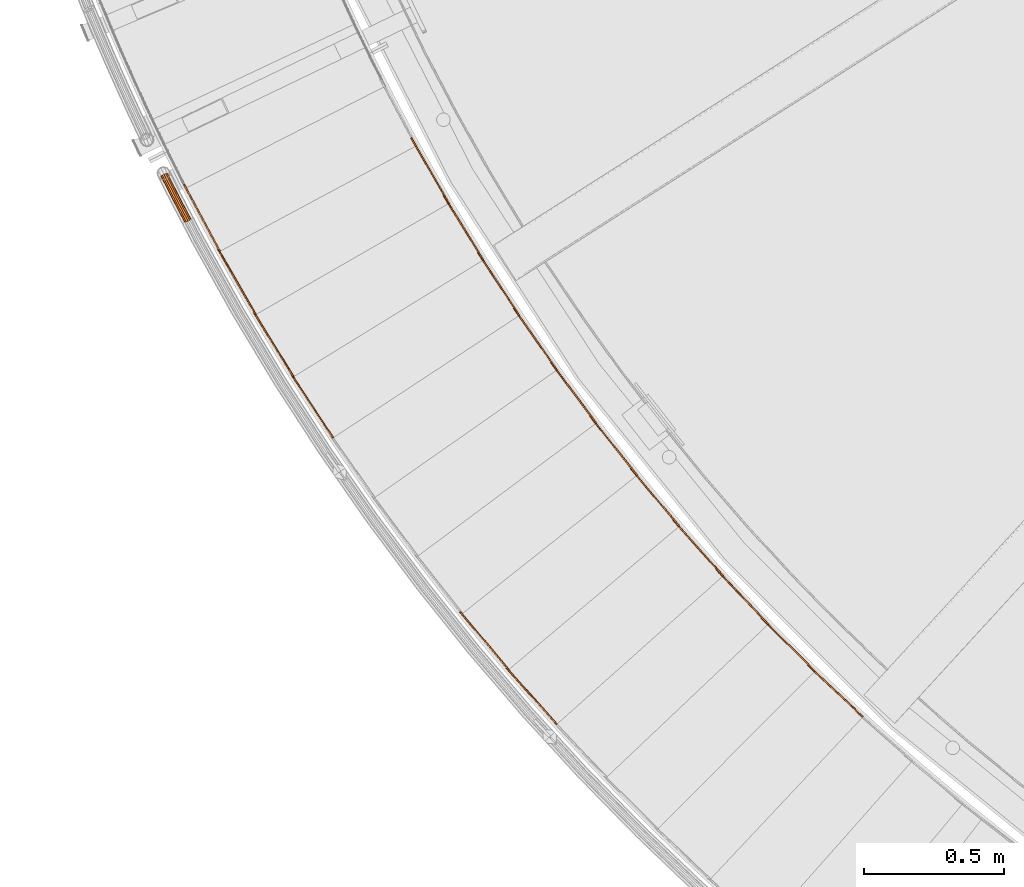
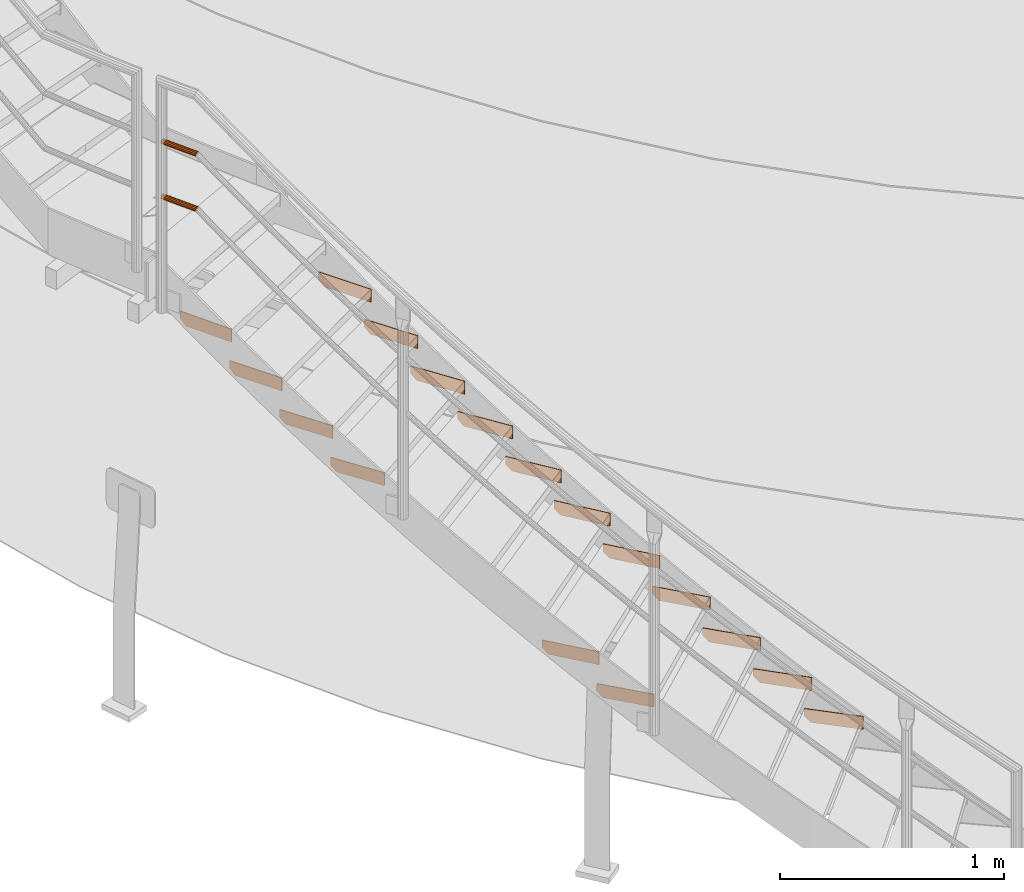
# One storey, part 45 of 126: 19 proxies.
"""IFC2X3 building model written with IfcOpenShell, lengths in millimetres."""

from ifc_helpers import new_model, si_unit, origin, origin_with_axes, place, context, project, spatial, faceted_brep, material, element, save


model = new_model("IFC2X3")

# Units and contexts
context_of_model_1 = context(None, 3, precision=0.1, world=origin())
context_of_model_2 = context(None, 3, precision=0.1, world=origin())
ifc_project = project(units=[si_unit("LENGTHUNIT", "METRE", prefix="MILLI"), si_unit("AREAUNIT", "SQUARE_METRE", prefix="CENTI"), si_unit("VOLUMEUNIT", "CUBIC_METRE", prefix="CENTI"), si_unit("MASSUNIT", "GRAM", prefix="KILO")], contexts=[context_of_model_1, context_of_model_2])

# Site, building, storey
site_placement = place(None, origin_with_axes())
site = spatial("IfcSite", under=ifc_project, at=site_placement, CompositionType="ELEMENT")
building_placement = place(site_placement, origin_with_axes())
building = spatial("IfcBuilding", under=site, at=building_placement, CompositionType="ELEMENT")
storey_placement = place(building_placement, origin_with_axes())
storey = spatial("IfcBuildingStorey", under=building, at=storey_placement, CompositionType="ELEMENT")

# Proxies
ifc_material = material(Name="S235JRG2")
proxy_1_placement = place(storey_placement, origin_with_axes())
element("IfcBuildingElementProxy", 1, at=proxy_1_placement, inside=storey, material=ifc_material, context=context_of_model_2, shape_type="Brep", body=[
    faceted_brep([(2566.2989, 2108.1136, 622.69), (2569.7223, 2111.7578, 622.69), (2569.7223, 2111.7578, 692.69), (2566.2989, 2108.1136, 692.69), (2369.5096, 2292.9755, 692.69), (2372.9329, 2296.6198, 692.69), (2372.9329, 2296.6198, 652.69), (2369.5096, 2292.9755, 652.69), (2391.375, 2272.4353, 622.69), (2394.7984, 2276.0795, 622.69)], [[[0, 1, 2, 3]], [[4, 5, 6, 7]], [[0, 8, 9, 1]], [[1, 9, 6, 5, 2]], [[2, 5, 4, 3]], [[0, 3, 4, 7, 8]], [[6, 9, 8, 7]]]),
])
proxy_2_placement = place(storey_placement, origin_with_axes())
element("IfcBuildingElementProxy", 2, at=proxy_2_placement, inside=storey, material=ifc_material, context=context_of_model_2, shape_type="Brep", body=[
    faceted_brep([(2395.0892, 2270.7485, 795.85), (2398.6183, 2274.2905, 795.85), (2398.6183, 2274.2905, 865.85), (2395.0892, 2270.7485, 865.85), (2203.8262, 2461.3226, 865.85), (2207.3554, 2464.8645, 865.85), (2207.3554, 2464.8645, 825.85), (2203.8262, 2461.3226, 825.85), (2225.0777, 2440.1477, 795.85), (2228.6068, 2443.6896, 795.85)], [[[0, 1, 2, 3]], [[4, 5, 6, 7]], [[0, 8, 9, 1]], [[1, 9, 6, 5, 2]], [[2, 5, 4, 3]], [[0, 3, 4, 7, 8]], [[6, 9, 8, 7]]]),
])
proxy_3_placement = place(storey_placement, origin_with_axes())
element("IfcBuildingElementProxy", 3, at=proxy_3_placement, inside=storey, material=ifc_material, context=context_of_model_2, shape_type="Brep", body=[
    faceted_brep([(2228.7405, 2438.3524, 969.01), (2232.3724, 2441.7889, 969.01), (2232.3724, 2441.7889, 1039.01), (2228.7405, 2438.3524, 1039.01), (2043.1697, 2634.4734, 1039.01), (2046.8016, 2637.9099, 1039.01), (2046.8016, 2637.9099, 999.01), (2043.1697, 2634.4734, 999.01), (2063.7887, 2612.6822, 969.01), (2067.4205, 2616.1187, 969.01)], [[[0, 1, 2, 3]], [[4, 5, 6, 7]], [[0, 8, 9, 1]], [[1, 9, 6, 5, 2]], [[2, 5, 4, 3]], [[0, 3, 4, 7, 8]], [[6, 9, 8, 7]]]),
])
proxy_4_placement = place(storey_placement, origin_with_axes())
element("IfcBuildingElementProxy", 4, at=proxy_4_placement, inside=storey, material=ifc_material, context=context_of_model_2, shape_type="Brep", body=[
    faceted_brep([(2067.3971, 2610.7798, 1142.17), (2071.1286, 2614.1079, 1142.17), (2071.1286, 2614.1079, 1212.17), (2067.3971, 2610.7798, 1212.17), (1887.6792, 2812.2779, 1212.17), (1891.4107, 2815.606, 1212.17), (1891.4107, 2815.606, 1172.17), (1887.6792, 2812.2779, 1172.17), (1907.6479, 2789.8892, 1142.17), (1911.3793, 2793.2173, 1142.17)], [[[0, 1, 2, 3]], [[4, 5, 6, 7]], [[0, 8, 9, 1]], [[1, 9, 6, 5, 2]], [[2, 5, 4, 3]], [[0, 3, 4, 7, 8]], [[6, 9, 8, 7]]]),
])
proxy_5_placement = place(storey_placement, origin_with_axes())
element("IfcBuildingElementProxy", 5, at=proxy_5_placement, inside=storey, material=ifc_material, context=context_of_model_2, shape_type="Brep", body=[
    faceted_brep([(1474.0973, 2081.6104, 1142.17), (1477.8287, 2084.9385, 1142.17), (1477.8287, 2084.9385, 1212.17), (1474.0973, 2081.6104, 1212.17), (1294.3793, 2283.1085, 1212.17), (1298.1108, 2286.4366, 1212.17), (1298.1108, 2286.4366, 1172.17), (1294.3793, 2283.1085, 1172.17), (1314.348, 2260.7198, 1142.17), (1318.0794, 2264.0479, 1142.17)], [[[0, 1, 2, 3]], [[4, 5, 6, 7]], [[0, 8, 9, 1]], [[1, 9, 6, 5, 2]], [[2, 5, 4, 3]], [[0, 3, 4, 7, 8]], [[6, 9, 8, 7]]]),
])
proxy_6_placement = place(storey_placement, origin_with_axes())
element("IfcBuildingElementProxy", 6, at=proxy_6_placement, inside=storey, material=ifc_material, context=context_of_model_2, shape_type="Brep", body=[
    faceted_brep([(1911.1988, 2787.8815, 1315.33), (1915.0266, 2791.0983, 1315.33), (1915.0266, 2791.0983, 1385.33), (1911.1988, 2787.8815, 1385.33), (1737.4895, 2994.582, 1385.33), (1741.3173, 2997.7988, 1385.33), (1741.3173, 2997.7988, 1345.33), (1737.4895, 2994.582, 1345.33), (1756.7906, 2971.6153, 1315.33), (1760.6183, 2974.8321, 1315.33)], [[[0, 1, 2, 3]], [[4, 5, 6, 7]], [[0, 8, 9, 1]], [[1, 9, 6, 5, 2]], [[2, 5, 4, 3]], [[0, 3, 4, 7, 8]], [[6, 9, 8, 7]]]),
])
proxy_7_placement = place(storey_placement, origin_with_axes())
element("IfcBuildingElementProxy", 7, at=proxy_7_placement, inside=storey, material=ifc_material, context=context_of_model_2, shape_type="Brep", body=[
    faceted_brep([(1302.5806, 2276.4042, 1315.33), (1306.4084, 2279.6211, 1315.33), (1306.4084, 2279.6211, 1385.33), (1302.5806, 2276.4042, 1385.33), (1128.8714, 2483.1047, 1385.33), (1132.6992, 2486.3216, 1385.33), (1132.6992, 2486.3216, 1345.33), (1128.8714, 2483.1047, 1345.33), (1148.1724, 2460.138, 1315.33), (1152.0002, 2463.3549, 1315.33)], [[[0, 1, 2, 3]], [[4, 5, 6, 7]], [[0, 8, 9, 1]], [[1, 9, 6, 5, 2]], [[2, 5, 4, 3]], [[0, 3, 4, 7, 8]], [[6, 9, 8, 7]]]),
])
proxy_8_placement = place(storey_placement, origin_with_axes())
element("IfcBuildingElementProxy", 8, at=proxy_8_placement, inside=storey, material=ifc_material, context=context_of_model_2, shape_type="Brep", body=[
    faceted_brep([(1760.2808, 2969.5039, 1488.49), (1764.2016, 2972.6066, 1488.49), (1764.2016, 2972.6066, 1558.49), (1760.2808, 2969.5039, 1558.49), (1592.7308, 3181.2277, 1558.49), (1596.6516, 3184.3305, 1558.49), (1596.6516, 3184.3305, 1518.49), (1592.7308, 3181.2277, 1518.49), (1611.3474, 3157.7028, 1488.49), (1615.2682, 3160.8056, 1488.49)], [[[0, 1, 2, 3]], [[4, 5, 6, 7]], [[0, 8, 9, 1]], [[1, 9, 6, 5, 2]], [[2, 5, 4, 3]], [[0, 3, 4, 7, 8]], [[6, 9, 8, 7]]]),
])
proxy_9_placement = place(storey_placement, origin_with_axes())
element("IfcBuildingElementProxy", 9, at=proxy_9_placement, inside=storey, material=ifc_material, context=context_of_model_2, shape_type="Brep", body=[
    faceted_brep([(1614.774, 3155.4896, 1661.65), (1618.7845, 3158.4756, 1661.65), (1618.7845, 3158.4756, 1731.65), (1614.774, 3155.4896, 1731.65), (1453.5283, 3372.0533, 1731.65), (1457.5388, 3375.0393, 1731.65), (1457.5388, 3375.0393, 1691.65), (1453.5283, 3372.0533, 1691.65), (1471.4445, 3347.9906, 1661.65), (1475.455, 3350.9767, 1661.65)], [[[0, 1, 2, 3]], [[4, 5, 6, 7]], [[0, 8, 9, 1]], [[1, 9, 6, 5, 2]], [[2, 5, 4, 3]], [[0, 3, 4, 7, 8]], [[6, 9, 8, 7]]]),
])
proxy_10_placement = place(storey_placement, origin_with_axes())
element("IfcBuildingElementProxy", 10, at=proxy_10_placement, inside=storey, material=ifc_material, context=context_of_model_2, shape_type="Brep", body=[
    faceted_brep([(1474.8045, 3345.6775, 1834.81), (1478.9011, 3348.5442, 1834.81), (1478.9011, 3348.5442, 1904.81), (1474.8045, 3345.6775, 1904.81), (1320.0029, 3566.8934, 1904.81), (1324.0995, 3569.7601, 1904.81), (1324.0995, 3569.7601, 1864.81), (1320.0029, 3566.8934, 1864.81), (1337.2031, 3542.3139, 1834.81), (1341.2997, 3545.1806, 1834.81)], [[[0, 1, 2, 3]], [[4, 5, 6, 7]], [[0, 8, 9, 1]], [[1, 9, 6, 5, 2]], [[2, 5, 4, 3]], [[0, 3, 4, 7, 8]], [[6, 9, 8, 7]]]),
])
proxy_11_placement = place(storey_placement, origin_with_axes())
element("IfcBuildingElementProxy", 11, at=proxy_11_placement, inside=storey, material=ifc_material, context=context_of_model_2, shape_type="Brep", body=[
    faceted_brep([(1340.4935, 3539.9029, 2007.97), (1344.6727, 3542.6477, 2007.97), (1344.6727, 3542.6477, 2077.97), (1340.4935, 3539.9029, 2077.97), (1192.2702, 3765.5792, 2077.97), (1196.4493, 3768.3241, 2077.97), (1196.4493, 3768.3241, 2037.97), (1192.2702, 3765.5792, 2037.97), (1208.7394, 3740.5041, 2007.97), (1212.9186, 3743.249, 2007.97)], [[[0, 1, 2, 3]], [[4, 5, 6, 7]], [[0, 8, 9, 1]], [[1, 9, 6, 5, 2]], [[2, 5, 4, 3]], [[0, 3, 4, 7, 8]], [[6, 9, 8, 7]]]),
])
proxy_12_placement = place(storey_placement, origin_with_axes())
element("IfcBuildingElementProxy", 12, at=proxy_12_placement, inside=storey, material=ifc_material, context=context_of_model_2, shape_type="Brep", body=[
    faceted_brep([(676.0019, 3103.4674, 2007.97), (680.1811, 3106.2123, 2007.97), (680.1811, 3106.2123, 2077.97), (676.0019, 3103.4674, 2077.97), (527.7786, 3329.1438, 2077.97), (531.9578, 3331.8886, 2077.97), (531.9578, 3331.8886, 2037.97), (527.7786, 3329.1438, 2037.97), (544.2478, 3304.0686, 2007.97), (548.427, 3306.8135, 2007.97)], [[[0, 1, 2, 3]], [[4, 5, 6, 7]], [[0, 8, 9, 1]], [[1, 9, 6, 5, 2]], [[2, 5, 4, 3]], [[0, 3, 4, 7, 8]], [[6, 9, 8, 7]]]),
])
proxy_13_placement = place(storey_placement, origin_with_axes())
element("IfcBuildingElementProxy", 13, at=proxy_13_placement, inside=storey, material=ifc_material, context=context_of_model_2, shape_type="Brep", body=[
    faceted_brep([(1211.9575, 3737.9973, 2181.13), (1216.2156, 3740.618, 2181.13), (1216.2156, 3740.618, 2251.13), (1211.9575, 3737.9973, 2251.13), (1070.4408, 3967.9386, 2251.13), (1074.6989, 3970.5593, 2251.13), (1074.6989, 3970.5593, 2211.13), (1070.4408, 3967.9386, 2211.13), (1086.1648, 3942.3896, 2181.13), (1090.423, 3945.0103, 2181.13)], [[[0, 1, 2, 3]], [[4, 5, 6, 7]], [[0, 8, 9, 1]], [[1, 9, 6, 5, 2]], [[2, 5, 4, 3]], [[0, 3, 4, 7, 8]], [[6, 9, 8, 7]]]),
])
proxy_14_placement = place(storey_placement, origin_with_axes())
element("IfcBuildingElementProxy", 14, at=proxy_14_placement, inside=storey, material=ifc_material, context=context_of_model_2, shape_type="Brep", body=[
    faceted_brep([(534.9079, 3321.3092, 2181.13), (539.1661, 3323.9299, 2181.13), (539.1661, 3323.9299, 2251.13), (534.9079, 3321.3092, 2251.13), (393.3912, 3551.2506, 2251.13), (397.6494, 3553.8712, 2251.13), (397.6494, 3553.8712, 2211.13), (393.3912, 3551.2506, 2211.13), (409.1153, 3525.7015, 2181.13), (413.3735, 3528.3222, 2181.13)], [[[0, 1, 2, 3]], [[4, 5, 6, 7]], [[0, 8, 9, 1]], [[1, 9, 6, 5, 2]], [[2, 5, 4, 3]], [[0, 3, 4, 7, 8]], [[6, 9, 8, 7]]]),
])
proxy_15_placement = place(storey_placement, origin_with_axes())
element("IfcBuildingElementProxy", 15, at=proxy_15_placement, inside=storey, material=ifc_material, context=context_of_model_2, shape_type="Brep", body=[
    faceted_brep([(1089.3077, 3939.7891, 2354.29), (1093.6412, 3942.2834, 2354.29), (1093.6412, 3942.2834, 2424.29), (1089.3077, 3939.7891, 2424.29), (954.6203, 4173.7962, 2424.29), (958.9538, 4176.2904, 2424.29), (958.9538, 4176.2904, 2384.29), (954.6203, 4173.7962, 2384.29), (969.5856, 4147.7954, 2354.29), (973.919, 4150.2896, 2354.29)], [[[0, 1, 2, 3]], [[4, 5, 6, 7]], [[0, 8, 9, 1]], [[1, 9, 6, 5, 2]], [[2, 5, 4, 3]], [[0, 3, 4, 7, 8]], [[6, 9, 8, 7]]]),
])
proxy_16_placement = place(storey_placement, origin_with_axes())
element("IfcBuildingElementProxy", 16, at=proxy_16_placement, inside=storey, material=ifc_material, context=context_of_model_2, shape_type="Brep", body=[
    faceted_brep([(400.2869, 3543.2096, 2354.29), (404.6204, 3545.7038, 2354.29), (404.6204, 3545.7038, 2424.29), (400.2869, 3543.2096, 2424.29), (265.5995, 3777.2166, 2424.29), (269.933, 3779.7108, 2424.29), (269.933, 3779.7108, 2384.29), (265.5995, 3777.2166, 2384.29), (280.5648, 3751.2158, 2354.29), (284.8983, 3753.7101, 2354.29)], [[[0, 1, 2, 3]], [[4, 5, 6, 7]], [[0, 8, 9, 1]], [[1, 9, 6, 5, 2]], [[2, 5, 4, 3]], [[0, 3, 4, 7, 8]], [[6, 9, 8, 7]]]),
])
proxy_17_placement = place(storey_placement, origin_with_axes())
element("IfcBuildingElementProxy", 17, at=proxy_17_placement, inside=storey, material=ifc_material, context=context_of_model_2, shape_type="Brep", body=[
    faceted_brep([(272.2556, 3768.9761, 2527.45), (276.6606, 3771.3417, 2527.45), (276.6606, 3771.3417, 2597.45), (272.2556, 3768.9761, 2597.45), (144.5142, 4006.8461, 2597.45), (148.9192, 4009.2117, 2597.45), (148.9192, 4009.2117, 2557.45), (144.5142, 4006.8461, 2557.45), (158.7076, 3980.4161, 2527.45), (163.1126, 3982.7817, 2527.45)], [[[0, 1, 2, 3]], [[4, 5, 6, 7]], [[0, 8, 9, 1]], [[1, 9, 6, 5, 2]], [[2, 5, 4, 3]], [[0, 3, 4, 7, 8]], [[6, 9, 8, 7]]]),
])
proxy_18_placement = place(storey_placement, origin_with_axes())
element("IfcBuildingElementProxy", 18, at=proxy_18_placement, inside=storey, material=ifc_material, context=context_of_model_2, shape_type="Brep", body=[
    faceted_brep([(68.0416, 4028.605, 3524.2551), (62.8151, 4039.041, 3524.2551), (64.446, 4039.8085, 3517.5301), (69.6514, 4029.4147, 3517.5301), (68.9018, 4041.9055, 3512.607), (74.0494, 4031.6269, 3512.607), (74.9884, 4044.7699, 3510.8051), (80.0572, 4034.6489, 3510.8051), (81.0751, 4047.6344, 3512.607), (86.065, 4037.6708, 3512.607), (85.5308, 4049.7313, 3517.5301), (90.463, 4039.883, 3517.5301), (87.1617, 4050.4989, 3524.2551), (92.0728, 4040.6927, 3524.2551), (85.5308, 4049.7313, 3530.9801), (90.463, 4039.883, 3530.9801), (81.0751, 4047.6344, 3535.9031), (86.065, 4037.6708, 3535.9031), (74.9884, 4044.7699, 3537.7051), (80.0572, 4034.6489, 3537.7051), (68.9018, 4041.9055, 3535.9031), (74.0494, 4031.6269, 3535.9031), (64.446, 4039.8085, 3530.9801), (69.6514, 4029.4147, 3530.9801), (69.8283, 4029.5037, 3524.2551), (64.6253, 4039.8929, 3524.2551), (66.0137, 4040.5463, 3529.9801), (71.1987, 4030.1931, 3529.9801), (69.8068, 4042.3314, 3534.1711), (74.9427, 4032.0763, 3534.1711), (74.9884, 4044.7699, 3535.7051), (80.0572, 4034.6489, 3535.7051), (80.17, 4047.2085, 3534.1711), (85.1716, 4037.2214, 3534.1711), (83.9632, 4048.9936, 3529.9801), (88.9157, 4039.1047, 3529.9801), (85.3516, 4049.647, 3524.2551), (90.2861, 4039.794, 3524.2551), (83.9632, 4048.9936, 3518.5301), (88.9157, 4039.1047, 3518.5301), (80.17, 4047.2085, 3514.3391), (85.1716, 4037.2214, 3514.3391), (74.9884, 4044.7699, 3512.8051), (80.0572, 4034.6489, 3512.8051), (69.8068, 4042.3314, 3514.3391), (74.9427, 4032.0763, 3514.3391), (66.0137, 4040.5463, 3518.5301), (71.1987, 4030.1931, 3518.5301), (83.6215, 4001.7613, 3517.5301), (82.0146, 4000.946, 3524.2551), (88.0118, 4003.9889, 3512.607), (94.009, 4007.0317, 3510.8051), (100.0062, 4010.0746, 3512.607), (104.3965, 4012.3021, 3517.5301), (106.0035, 4013.1175, 3524.2551), (104.3965, 4012.3021, 3530.9801), (100.0062, 4010.0746, 3535.9031), (94.009, 4007.0317, 3537.7051), (88.0118, 4003.9889, 3535.9031), (83.6215, 4001.7613, 3530.9801), (85.1661, 4002.545, 3529.9801), (83.7981, 4001.8509, 3524.2551), (88.9036, 4004.4413, 3534.1711), (94.009, 4007.0317, 3535.7051), (99.1145, 4009.6221, 3534.1711), (102.8519, 4011.5184, 3529.9801), (104.2199, 4012.2125, 3524.2551), (102.8519, 4011.5184, 3518.5301), (99.1145, 4009.6221, 3514.3391), (94.009, 4007.0317, 3512.8051), (88.9036, 4004.4413, 3514.3391), (85.1661, 4002.545, 3518.5301), (97.6881, 3974.1568, 3517.5301), (96.084, 3973.3359, 3524.2551), (102.0706, 3976.3997, 3512.607), (108.0572, 3979.4635, 3510.8051), (114.0437, 3982.5273, 3512.607), (118.4262, 3984.7701, 3517.5301), (120.0303, 3985.591, 3524.2551), (118.4262, 3984.7701, 3530.9801), (114.0437, 3982.5273, 3535.9031), (108.0572, 3979.4635, 3537.7051), (102.0706, 3976.3997, 3535.9031), (97.6881, 3974.1568, 3530.9801), (99.23, 3974.9459, 3529.9801), (97.8644, 3974.2471, 3524.2551), (102.9608, 3976.8553, 3534.1711), (108.0572, 3979.4635, 3535.7051), (113.1535, 3982.0717, 3534.1711), (116.8843, 3983.981, 3529.9801), (118.2499, 3984.6799, 3524.2551), (116.8843, 3983.981, 3518.5301), (113.1535, 3982.0717, 3514.3391), (108.0572, 3979.4635, 3512.8051), (102.9608, 3976.8553, 3514.3391), (99.23, 3974.9459, 3518.5301), (111.851, 3946.6016, 3517.5301), (110.2498, 3945.7751, 3524.2551), (116.2256, 3948.8597, 3512.607), (122.2015, 3951.9444, 3510.8051), (128.1773, 3955.0291, 3512.607), (132.5519, 3957.2872, 3517.5301), (134.1531, 3958.1137, 3524.2551), (132.5519, 3957.2872, 3530.9801), (128.1773, 3955.0291, 3535.9031), (122.2015, 3951.9444, 3537.7051), (116.2256, 3948.8597, 3535.9031), (111.851, 3946.6016, 3530.9801), (113.3901, 3947.3961, 3529.9801), (112.027, 3946.6924, 3524.2551), (117.1142, 3949.3184, 3534.1711), (122.2015, 3951.9444, 3535.7051), (127.2887, 3954.5704, 3534.1711), (131.0128, 3956.4927, 3529.9801), (132.3759, 3957.1964, 3524.2551), (131.0128, 3956.4927, 3518.5301), (127.2887, 3954.5704, 3514.3391), (122.2015, 3951.9444, 3512.8051), (117.1142, 3949.3184, 3514.3391), (113.3901, 3947.3961, 3518.5301), (126.11, 3919.096, 3517.5301), (124.5117, 3918.2639, 3524.2551), (130.4767, 3921.3694, 3512.607), (136.4417, 3924.4749, 3510.8051), (142.4068, 3927.5804, 3512.607), (146.7735, 3929.8538, 3517.5301), (148.3718, 3930.6859, 3524.2551), (146.7735, 3929.8538, 3530.9801), (142.4068, 3927.5804, 3535.9031), (136.4417, 3924.4749, 3537.7051), (130.4767, 3921.3694, 3535.9031), (126.11, 3919.096, 3530.9801), (127.6463, 3919.8958, 3529.9801), (126.2857, 3919.1874, 3524.2551), (131.3637, 3921.8312, 3534.1711), (136.4417, 3924.4749, 3535.7051), (141.5198, 3927.1186, 3534.1711), (145.2372, 3929.054, 3529.9801), (146.5978, 3929.7623, 3524.2551), (145.2372, 3929.054, 3518.5301), (141.5198, 3927.1186, 3514.3391), (136.4417, 3924.4749, 3512.8051), (131.3637, 3921.8312, 3514.3391), (127.6463, 3919.8958, 3518.5301), (140.4649, 3891.6403, 3517.5301), (138.8695, 3890.8026, 3524.2551), (144.8236, 3893.9289, 3512.607), (150.7778, 3897.0553, 3510.8051), (156.732, 3900.1816, 3512.607), (161.0907, 3902.4702, 3517.5301), (162.6861, 3903.3079, 3524.2551), (161.0907, 3902.4702, 3530.9801), (156.732, 3900.1816, 3535.9031), (150.7778, 3897.0553, 3537.7051), (144.8236, 3893.9289, 3535.9031), (140.4649, 3891.6403, 3530.9801), (141.9984, 3892.4455, 3529.9801), (140.6402, 3891.7324, 3524.2551), (145.709, 3894.3938, 3534.1711), (150.7778, 3897.0553, 3535.7051), (155.8466, 3899.7167, 3534.1711), (159.5572, 3901.665, 3529.9801), (160.9154, 3902.3781, 3524.2551), (159.5572, 3901.665, 3518.5301), (155.8466, 3899.7167, 3514.3391), (150.7778, 3897.0553, 3512.8051), (145.709, 3894.3938, 3514.3391), (141.9984, 3892.4455, 3518.5301), (147.7547, 3877.8153, 3517.5301), (147.1292, 3875.1383, 3524.2551), (151.4497, 3881.3627, 3512.607), (157.2241, 3884.8299, 3510.8051), (163.5307, 3887.2879, 3512.607), (168.6795, 3888.0781, 3517.5301), (171.291, 3886.9888, 3524.2551), (170.6655, 3884.3118, 3530.9801), (166.9705, 3880.7644, 3535.9031), (161.1961, 3877.2972, 3537.7051), (154.8895, 3874.8392, 3535.9031), (149.7407, 3874.049, 3530.9801), (151.1488, 3875.092, 3529.9801), (148.9256, 3876.0194, 3524.2551), (155.532, 3875.7647, 3534.1711), (160.9008, 3877.8572, 3535.7051), (165.8165, 3880.8089, 3534.1711), (168.9621, 3883.8288, 3529.9801), (169.4946, 3886.1077, 3524.2551), (167.2714, 3887.0351, 3518.5301), (162.8882, 3886.3624, 3514.3391), (157.5195, 3884.2698, 3512.8051), (152.6037, 3881.3182, 3514.3391), (149.4581, 3878.2983, 3518.5301)], [[[0, 1, 2, 3]], [[3, 2, 4, 5]], [[5, 4, 6, 7]], [[7, 6, 8, 9]], [[9, 8, 10, 11]], [[11, 10, 12, 13]], [[13, 12, 14, 15]], [[15, 14, 16, 17]], [[17, 16, 18, 19]], [[19, 18, 20, 21]], [[21, 20, 22, 23]], [[0, 23, 22, 1]], [[24, 25, 26, 27]], [[27, 26, 28, 29]], [[29, 28, 30, 31]], [[31, 30, 32, 33]], [[33, 32, 34, 35]], [[35, 34, 36, 37]], [[37, 36, 38, 39]], [[39, 38, 40, 41]], [[41, 40, 42, 43]], [[43, 42, 44, 45]], [[45, 44, 46, 47]], [[24, 47, 46, 25]], [[0, 3, 48, 49]], [[3, 5, 50, 48]], [[5, 7, 51, 50]], [[7, 9, 52, 51]], [[9, 11, 53, 52]], [[11, 13, 54, 53]], [[13, 15, 55, 54]], [[15, 17, 56, 55]], [[17, 19, 57, 56]], [[19, 21, 58, 57]], [[21, 23, 59, 58]], [[23, 0, 49, 59]], [[24, 27, 60, 61]], [[27, 29, 62, 60]], [[29, 31, 63, 62]], [[31, 33, 64, 63]], [[33, 35, 65, 64]], [[35, 37, 66, 65]], [[37, 39, 67, 66]], [[39, 41, 68, 67]], [[41, 43, 69, 68]], [[43, 45, 70, 69]], [[45, 47, 71, 70]], [[47, 24, 61, 71]], [[49, 48, 72, 73]], [[48, 50, 74, 72]], [[50, 51, 75, 74]], [[51, 52, 76, 75]], [[52, 53, 77, 76]], [[53, 54, 78, 77]], [[54, 55, 79, 78]], [[55, 56, 80, 79]], [[56, 57, 81, 80]], [[57, 58, 82, 81]], [[58, 59, 83, 82]], [[59, 49, 73, 83]], [[61, 60, 84, 85]], [[60, 62, 86, 84]], [[62, 63, 87, 86]], [[63, 64, 88, 87]], [[64, 65, 89, 88]], [[65, 66, 90, 89]], [[66, 67, 91, 90]], [[67, 68, 92, 91]], [[68, 69, 93, 92]], [[69, 70, 94, 93]], [[70, 71, 95, 94]], [[71, 61, 85, 95]], [[73, 72, 96, 97]], [[72, 74, 98, 96]], [[74, 75, 99, 98]], [[75, 76, 100, 99]], [[76, 77, 101, 100]], [[77, 78, 102, 101]], [[78, 79, 103, 102]], [[79, 80, 104, 103]], [[80, 81, 105, 104]], [[81, 82, 106, 105]], [[82, 83, 107, 106]], [[83, 73, 97, 107]], [[85, 84, 108, 109]], [[84, 86, 110, 108]], [[86, 87, 111, 110]], [[87, 88, 112, 111]], [[88, 89, 113, 112]], [[89, 90, 114, 113]], [[90, 91, 115, 114]], [[91, 92, 116, 115]], [[92, 93, 117, 116]], [[93, 94, 118, 117]], [[94, 95, 119, 118]], [[95, 85, 109, 119]], [[97, 96, 120, 121]], [[96, 98, 122, 120]], [[98, 99, 123, 122]], [[99, 100, 124, 123]], [[100, 101, 125, 124]], [[101, 102, 126, 125]], [[102, 103, 127, 126]], [[103, 104, 128, 127]], [[104, 105, 129, 128]], [[105, 106, 130, 129]], [[106, 107, 131, 130]], [[107, 97, 121, 131]], [[109, 108, 132, 133]], [[108, 110, 134, 132]], [[110, 111, 135, 134]], [[111, 112, 136, 135]], [[112, 113, 137, 136]], [[113, 114, 138, 137]], [[114, 115, 139, 138]], [[115, 116, 140, 139]], [[116, 117, 141, 140]], [[117, 118, 142, 141]], [[118, 119, 143, 142]], [[119, 109, 133, 143]], [[121, 120, 144, 145]], [[120, 122, 146, 144]], [[122, 123, 147, 146]], [[123, 124, 148, 147]], [[124, 125, 149, 148]], [[125, 126, 150, 149]], [[126, 127, 151, 150]], [[127, 128, 152, 151]], [[128, 129, 153, 152]], [[129, 130, 154, 153]], [[130, 131, 155, 154]], [[131, 121, 145, 155]], [[133, 132, 156, 157]], [[132, 134, 158, 156]], [[134, 135, 159, 158]], [[135, 136, 160, 159]], [[136, 137, 161, 160]], [[137, 138, 162, 161]], [[138, 139, 163, 162]], [[139, 140, 164, 163]], [[140, 141, 165, 164]], [[141, 142, 166, 165]], [[142, 143, 167, 166]], [[143, 133, 157, 167]], [[144, 168, 169, 145]], [[144, 146, 170, 168]], [[146, 147, 171, 170]], [[147, 148, 172, 171]], [[148, 149, 173, 172]], [[149, 150, 174, 173]], [[150, 151, 175, 174]], [[151, 152, 176, 175]], [[152, 153, 177, 176]], [[153, 154, 178, 177]], [[154, 155, 179, 178]], [[145, 169, 179, 155]], [[156, 180, 181, 157]], [[156, 158, 182, 180]], [[158, 159, 183, 182]], [[159, 160, 184, 183]], [[160, 161, 185, 184]], [[161, 162, 186, 185]], [[162, 163, 187, 186]], [[163, 164, 188, 187]], [[164, 165, 189, 188]], [[165, 166, 190, 189]], [[166, 167, 191, 190]], [[157, 181, 191, 167]], [[6, 4, 2, 1, 22, 20, 18, 16, 14, 12, 10, 8], [26, 25, 46, 44, 42, 40, 38, 36, 34, 32, 30, 28]], [[177, 178, 179, 169, 168, 170, 171, 172, 173, 174, 175, 176], [180, 182, 183, 184, 185, 186, 187, 188, 189, 190, 191, 181]]]),
])
proxy_19_placement = place(storey_placement, origin_with_axes())
element("IfcBuildingElementProxy", 19, at=proxy_19_placement, inside=storey, material=ifc_material, context=context_of_model_2, shape_type="Brep", body=[
    faceted_brep([(68.0416, 4028.605, 3224.2551), (62.8151, 4039.041, 3224.2551), (64.446, 4039.8085, 3217.5301), (69.6514, 4029.4147, 3217.5301), (68.9018, 4041.9055, 3212.607), (74.0494, 4031.6269, 3212.607), (74.9884, 4044.7699, 3210.8051), (80.0572, 4034.6489, 3210.8051), (81.0751, 4047.6344, 3212.607), (86.065, 4037.6708, 3212.607), (85.5308, 4049.7313, 3217.5301), (90.463, 4039.883, 3217.5301), (87.1617, 4050.4989, 3224.2551), (92.0728, 4040.6927, 3224.2551), (85.5308, 4049.7313, 3230.9801), (90.463, 4039.883, 3230.9801), (81.0751, 4047.6344, 3235.9031), (86.065, 4037.6708, 3235.9031), (74.9884, 4044.7699, 3237.7051), (80.0572, 4034.6489, 3237.7051), (68.9018, 4041.9055, 3235.9031), (74.0494, 4031.6269, 3235.9031), (64.446, 4039.8085, 3230.9801), (69.6514, 4029.4147, 3230.9801), (69.8283, 4029.5037, 3224.2551), (64.6253, 4039.8929, 3224.2551), (66.0137, 4040.5463, 3229.9801), (71.1987, 4030.1931, 3229.9801), (69.8068, 4042.3314, 3234.1711), (74.9427, 4032.0763, 3234.1711), (74.9884, 4044.7699, 3235.7051), (80.0572, 4034.6489, 3235.7051), (80.17, 4047.2085, 3234.1711), (85.1716, 4037.2214, 3234.1711), (83.9632, 4048.9936, 3229.9801), (88.9157, 4039.1047, 3229.9801), (85.3516, 4049.647, 3224.2551), (90.2861, 4039.794, 3224.2551), (83.9632, 4048.9936, 3218.5301), (88.9157, 4039.1047, 3218.5301), (80.17, 4047.2085, 3214.3391), (85.1716, 4037.2214, 3214.3391), (74.9884, 4044.7699, 3212.8051), (80.0572, 4034.6489, 3212.8051), (69.8068, 4042.3314, 3214.3391), (74.9427, 4032.0763, 3214.3391), (66.0137, 4040.5463, 3218.5301), (71.1987, 4030.1931, 3218.5301), (83.6215, 4001.7613, 3217.5301), (82.0146, 4000.946, 3224.2551), (88.0118, 4003.9889, 3212.607), (94.009, 4007.0317, 3210.8051), (100.0062, 4010.0746, 3212.607), (104.3965, 4012.3021, 3217.5301), (106.0035, 4013.1175, 3224.2551), (104.3965, 4012.3021, 3230.9801), (100.0062, 4010.0746, 3235.9031), (94.009, 4007.0317, 3237.7051), (88.0118, 4003.9889, 3235.9031), (83.6215, 4001.7613, 3230.9801), (85.1661, 4002.545, 3229.9801), (83.7981, 4001.8509, 3224.2551), (88.9036, 4004.4413, 3234.1711), (94.009, 4007.0317, 3235.7051), (99.1145, 4009.6221, 3234.1711), (102.8519, 4011.5184, 3229.9801), (104.2199, 4012.2125, 3224.2551), (102.8519, 4011.5184, 3218.5301), (99.1145, 4009.6221, 3214.3391), (94.009, 4007.0317, 3212.8051), (88.9036, 4004.4413, 3214.3391), (85.1661, 4002.545, 3218.5301), (97.6881, 3974.1568, 3217.5301), (96.084, 3973.3359, 3224.2551), (102.0706, 3976.3997, 3212.607), (108.0572, 3979.4635, 3210.8051), (114.0437, 3982.5273, 3212.607), (118.4262, 3984.7701, 3217.5301), (120.0303, 3985.591, 3224.2551), (118.4262, 3984.7701, 3230.9801), (114.0437, 3982.5273, 3235.9031), (108.0572, 3979.4635, 3237.7051), (102.0706, 3976.3997, 3235.9031), (97.6881, 3974.1568, 3230.9801), (99.23, 3974.9459, 3229.9801), (97.8644, 3974.2471, 3224.2551), (102.9608, 3976.8553, 3234.1711), (108.0572, 3979.4635, 3235.7051), (113.1535, 3982.0717, 3234.1711), (116.8843, 3983.981, 3229.9801), (118.2499, 3984.6799, 3224.2551), (116.8843, 3983.981, 3218.5301), (113.1535, 3982.0717, 3214.3391), (108.0572, 3979.4635, 3212.8051), (102.9608, 3976.8553, 3214.3391), (99.23, 3974.9459, 3218.5301), (111.851, 3946.6016, 3217.5301), (110.2498, 3945.7751, 3224.2551), (116.2256, 3948.8597, 3212.607), (122.2015, 3951.9444, 3210.8051), (128.1773, 3955.0291, 3212.607), (132.5519, 3957.2872, 3217.5301), (134.1531, 3958.1137, 3224.2551), (132.5519, 3957.2872, 3230.9801), (128.1773, 3955.0291, 3235.9031), (122.2015, 3951.9444, 3237.7051), (116.2256, 3948.8597, 3235.9031), (111.851, 3946.6016, 3230.9801), (113.3901, 3947.3961, 3229.9801), (112.027, 3946.6924, 3224.2551), (117.1142, 3949.3184, 3234.1711), (122.2015, 3951.9444, 3235.7051), (127.2887, 3954.5704, 3234.1711), (131.0128, 3956.4927, 3229.9801), (132.3759, 3957.1964, 3224.2551), (131.0128, 3956.4927, 3218.5301), (127.2887, 3954.5704, 3214.3391), (122.2015, 3951.9444, 3212.8051), (117.1142, 3949.3184, 3214.3391), (113.3901, 3947.3961, 3218.5301), (126.11, 3919.096, 3217.5301), (124.5117, 3918.2639, 3224.2551), (130.4767, 3921.3694, 3212.607), (136.4417, 3924.4749, 3210.8051), (142.4068, 3927.5804, 3212.607), (146.7735, 3929.8538, 3217.5301), (148.3718, 3930.6859, 3224.2551), (146.7735, 3929.8538, 3230.9801), (142.4068, 3927.5804, 3235.9031), (136.4417, 3924.4749, 3237.7051), (130.4767, 3921.3694, 3235.9031), (126.11, 3919.096, 3230.9801), (127.6463, 3919.8958, 3229.9801), (126.2857, 3919.1874, 3224.2551), (131.3637, 3921.8312, 3234.1711), (136.4417, 3924.4749, 3235.7051), (141.5198, 3927.1186, 3234.1711), (145.2372, 3929.054, 3229.9801), (146.5978, 3929.7623, 3224.2551), (145.2372, 3929.054, 3218.5301), (141.5198, 3927.1186, 3214.3391), (136.4417, 3924.4749, 3212.8051), (131.3637, 3921.8312, 3214.3391), (127.6463, 3919.8958, 3218.5301), (140.4649, 3891.6403, 3217.5301), (138.8695, 3890.8026, 3224.2551), (144.8236, 3893.9289, 3212.607), (150.7778, 3897.0553, 3210.8051), (156.732, 3900.1816, 3212.607), (161.0907, 3902.4702, 3217.5301), (162.6861, 3903.3079, 3224.2551), (161.0907, 3902.4702, 3230.9801), (156.732, 3900.1816, 3235.9031), (150.7778, 3897.0553, 3237.7051), (144.8236, 3893.9289, 3235.9031), (140.4649, 3891.6403, 3230.9801), (141.9984, 3892.4455, 3229.9801), (140.6402, 3891.7324, 3224.2551), (145.709, 3894.3938, 3234.1711), (150.7778, 3897.0553, 3235.7051), (155.8466, 3899.7167, 3234.1711), (159.5572, 3901.665, 3229.9801), (160.9154, 3902.3781, 3224.2551), (159.5572, 3901.665, 3218.5301), (155.8466, 3899.7167, 3214.3391), (150.7778, 3897.0553, 3212.8051), (145.709, 3894.3938, 3214.3391), (141.9984, 3892.4455, 3218.5301), (147.7547, 3877.8153, 3217.5301), (147.1292, 3875.1383, 3224.2551), (151.4497, 3881.3627, 3212.607), (157.2241, 3884.8299, 3210.8051), (163.5307, 3887.2879, 3212.607), (168.6795, 3888.0781, 3217.5301), (171.291, 3886.9888, 3224.2551), (170.6655, 3884.3118, 3230.9801), (166.9705, 3880.7644, 3235.9031), (161.1961, 3877.2972, 3237.7051), (154.8895, 3874.8392, 3235.9031), (149.7407, 3874.049, 3230.9801), (151.1488, 3875.092, 3229.9801), (148.9256, 3876.0194, 3224.2551), (155.532, 3875.7647, 3234.1711), (160.9008, 3877.8572, 3235.7051), (165.8165, 3880.8089, 3234.1711), (168.9621, 3883.8288, 3229.9801), (169.4946, 3886.1077, 3224.2551), (167.2714, 3887.0351, 3218.5301), (162.8882, 3886.3624, 3214.3391), (157.5195, 3884.2698, 3212.8051), (152.6037, 3881.3182, 3214.3391), (149.4581, 3878.2983, 3218.5301)], [[[0, 1, 2, 3]], [[3, 2, 4, 5]], [[5, 4, 6, 7]], [[7, 6, 8, 9]], [[9, 8, 10, 11]], [[11, 10, 12, 13]], [[13, 12, 14, 15]], [[15, 14, 16, 17]], [[17, 16, 18, 19]], [[19, 18, 20, 21]], [[21, 20, 22, 23]], [[0, 23, 22, 1]], [[24, 25, 26, 27]], [[27, 26, 28, 29]], [[29, 28, 30, 31]], [[31, 30, 32, 33]], [[33, 32, 34, 35]], [[35, 34, 36, 37]], [[37, 36, 38, 39]], [[39, 38, 40, 41]], [[41, 40, 42, 43]], [[43, 42, 44, 45]], [[45, 44, 46, 47]], [[24, 47, 46, 25]], [[0, 3, 48, 49]], [[3, 5, 50, 48]], [[5, 7, 51, 50]], [[7, 9, 52, 51]], [[9, 11, 53, 52]], [[11, 13, 54, 53]], [[13, 15, 55, 54]], [[15, 17, 56, 55]], [[17, 19, 57, 56]], [[19, 21, 58, 57]], [[21, 23, 59, 58]], [[23, 0, 49, 59]], [[24, 27, 60, 61]], [[27, 29, 62, 60]], [[29, 31, 63, 62]], [[31, 33, 64, 63]], [[33, 35, 65, 64]], [[35, 37, 66, 65]], [[37, 39, 67, 66]], [[39, 41, 68, 67]], [[41, 43, 69, 68]], [[43, 45, 70, 69]], [[45, 47, 71, 70]], [[47, 24, 61, 71]], [[49, 48, 72, 73]], [[48, 50, 74, 72]], [[50, 51, 75, 74]], [[51, 52, 76, 75]], [[52, 53, 77, 76]], [[53, 54, 78, 77]], [[54, 55, 79, 78]], [[55, 56, 80, 79]], [[56, 57, 81, 80]], [[57, 58, 82, 81]], [[58, 59, 83, 82]], [[59, 49, 73, 83]], [[61, 60, 84, 85]], [[60, 62, 86, 84]], [[62, 63, 87, 86]], [[63, 64, 88, 87]], [[64, 65, 89, 88]], [[65, 66, 90, 89]], [[66, 67, 91, 90]], [[67, 68, 92, 91]], [[68, 69, 93, 92]], [[69, 70, 94, 93]], [[70, 71, 95, 94]], [[71, 61, 85, 95]], [[73, 72, 96, 97]], [[72, 74, 98, 96]], [[74, 75, 99, 98]], [[75, 76, 100, 99]], [[76, 77, 101, 100]], [[77, 78, 102, 101]], [[78, 79, 103, 102]], [[79, 80, 104, 103]], [[80, 81, 105, 104]], [[81, 82, 106, 105]], [[82, 83, 107, 106]], [[83, 73, 97, 107]], [[85, 84, 108, 109]], [[84, 86, 110, 108]], [[86, 87, 111, 110]], [[87, 88, 112, 111]], [[88, 89, 113, 112]], [[89, 90, 114, 113]], [[90, 91, 115, 114]], [[91, 92, 116, 115]], [[92, 93, 117, 116]], [[93, 94, 118, 117]], [[94, 95, 119, 118]], [[95, 85, 109, 119]], [[97, 96, 120, 121]], [[96, 98, 122, 120]], [[98, 99, 123, 122]], [[99, 100, 124, 123]], [[100, 101, 125, 124]], [[101, 102, 126, 125]], [[102, 103, 127, 126]], [[103, 104, 128, 127]], [[104, 105, 129, 128]], [[105, 106, 130, 129]], [[106, 107, 131, 130]], [[107, 97, 121, 131]], [[109, 108, 132, 133]], [[108, 110, 134, 132]], [[110, 111, 135, 134]], [[111, 112, 136, 135]], [[112, 113, 137, 136]], [[113, 114, 138, 137]], [[114, 115, 139, 138]], [[115, 116, 140, 139]], [[116, 117, 141, 140]], [[117, 118, 142, 141]], [[118, 119, 143, 142]], [[119, 109, 133, 143]], [[121, 120, 144, 145]], [[120, 122, 146, 144]], [[122, 123, 147, 146]], [[123, 124, 148, 147]], [[124, 125, 149, 148]], [[125, 126, 150, 149]], [[126, 127, 151, 150]], [[127, 128, 152, 151]], [[128, 129, 153, 152]], [[129, 130, 154, 153]], [[130, 131, 155, 154]], [[131, 121, 145, 155]], [[133, 132, 156, 157]], [[132, 134, 158, 156]], [[134, 135, 159, 158]], [[135, 136, 160, 159]], [[136, 137, 161, 160]], [[137, 138, 162, 161]], [[138, 139, 163, 162]], [[139, 140, 164, 163]], [[140, 141, 165, 164]], [[141, 142, 166, 165]], [[142, 143, 167, 166]], [[143, 133, 157, 167]], [[144, 168, 169, 145]], [[144, 146, 170, 168]], [[146, 147, 171, 170]], [[147, 148, 172, 171]], [[148, 149, 173, 172]], [[149, 150, 174, 173]], [[150, 151, 175, 174]], [[151, 152, 176, 175]], [[152, 153, 177, 176]], [[153, 154, 178, 177]], [[154, 155, 179, 178]], [[145, 169, 179, 155]], [[156, 180, 181, 157]], [[156, 158, 182, 180]], [[158, 159, 183, 182]], [[159, 160, 184, 183]], [[160, 161, 185, 184]], [[161, 162, 186, 185]], [[162, 163, 187, 186]], [[163, 164, 188, 187]], [[164, 165, 189, 188]], [[165, 166, 190, 189]], [[166, 167, 191, 190]], [[157, 181, 191, 167]], [[6, 4, 2, 1, 22, 20, 18, 16, 14, 12, 10, 8], [26, 25, 46, 44, 42, 40, 38, 36, 34, 32, 30, 28]], [[177, 178, 179, 169, 168, 170, 171, 172, 173, 174, 175, 176], [180, 182, 183, 184, 185, 186, 187, 188, 189, 190, 191, 181]]]),
])

save(model, "model.ifc")
